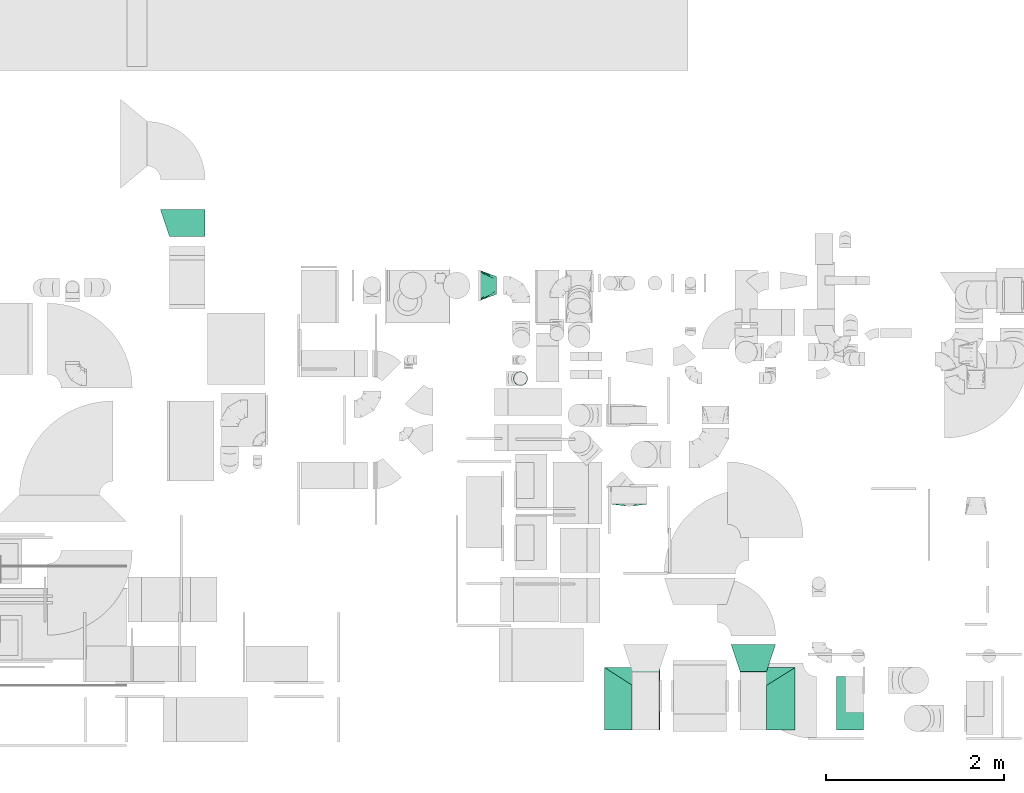
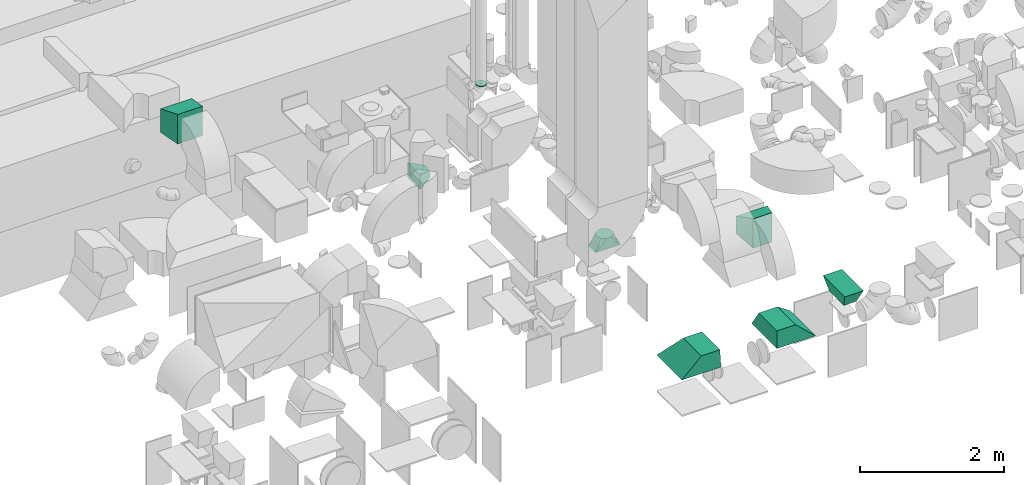
# One storey, part 53 of 59: 8 flow fittings.
"""IFC2X3 building model written with IfcOpenShell, lengths in millimetres."""

import ifcopenshell
import ifcopenshell.guid

model = None  # the IFC model being written
_history = None  # IfcOwnerHistory: only IFC2X3 demands one
_inside = {}  # id of a spatial element -> (the spatial element, [elements in it])
_under = {}  # id of a project, library or spatial element -> (it, [spatial elements below it])
_declared = {}  # id of a project -> (the project, [libraries it declares])
_typed = {}  # id of a type object -> (the type object, [elements of that type])
_made_of = {}  # id of a material, layer set ... -> (it, [elements and type objects made of it])


def new_model(schema):
    """Start an empty IFC model of exactly this schema.

    Asked for "IFC4X3", IfcOpenShell would pick the latest addendum, in which some entities
    have other attributes; the version numbers below select the first issue.
    IFC2X3 requires an IfcOwnerHistory on every rooted entity: one is made here for all.
    """
    global model, _history
    if schema == "IFC4X3":
        model = ifcopenshell.file(schema_version=(4, 3, 0, 0))
    else:
        model = ifcopenshell.file(schema=schema)
    _inside.clear()
    _under.clear()
    _declared.clear()
    _typed.clear()
    _made_of.clear()
    _history = None
    if model.schema == "IFC2X3":
        org = make("IfcOrganization", Name="unknown")
        user = make(
            "IfcPersonAndOrganization",
            ThePerson=make("IfcPerson", FamilyName="unknown"),
            TheOrganization=org,
        )
        app = make(
            "IfcApplication",
            ApplicationDeveloper=org,
            Version="unknown",
            ApplicationFullName="unknown",
            ApplicationIdentifier="unknown",
        )
        _history = make(
            "IfcOwnerHistory",
            OwningUser=user,
            OwningApplication=app,
            ChangeAction="ADDED",
            CreationDate=0,
        )
    return model


def make(cls, **values):
    """One entity of the class cls with the attributes given. An attribute that is None is left unset."""
    return model.create_entity(
        cls, **{name: value for name, value in values.items() if value is not None}
    )


def entity(cls, *values):
    """Any entity or typed value of the class cls, its attributes in the order of the schema. None: left unset."""
    e = model.create_entity(cls)
    for i, value in enumerate(values):
        if value is not None:
            e[i] = value
    return e


def rooted(cls, **values):
    """An entity with a GlobalId (a new one), such as an element, a storey or a relation."""
    return make(cls, GlobalId=ifcopenshell.guid.new(), OwnerHistory=_history, **values)


def si_unit(unit_type, name, prefix=None):
    """IfcSIUnit, for example si_unit("LENGTHUNIT", "METRE", prefix="MILLI")."""
    return make("IfcSIUnit", UnitType=unit_type, Prefix=prefix, Name=name)


def converted_unit(unit_type, name, factor, base, dimensions=None, offset=None):
    """IfcConversionBasedUnit, such as the inch: factor (a typed value) times the base unit."""
    return make(
        "IfcConversionBasedUnit"
        if offset is None
        else "IfcConversionBasedUnitWithOffset",
        ConversionOffset=offset,
        Dimensions=None
        if dimensions is None
        else entity("IfcDimensionalExponents", *dimensions),
        UnitType=unit_type,
        Name=name,
        ConversionFactor=make(
            "IfcMeasureWithUnit", ValueComponent=factor, UnitComponent=base
        ),
    )


def derived_unit(unit_type, elements):
    """IfcDerivedUnit: a product of units, each with its exponent."""
    return make(
        "IfcDerivedUnit",
        Elements=[
            make("IfcDerivedUnitElement", Unit=unit, Exponent=power)
            for unit, power in elements
        ],
        UnitType=unit_type,
    )


def assignment(units):
    """IfcUnitAssignment: the units of a project."""
    return None if units is None else make("IfcUnitAssignment", Units=units)


def point(xyz):
    """IfcCartesianPoint."""
    return None if xyz is None else make("IfcCartesianPoint", Coordinates=xyz)


def direction(xyz):
    """IfcDirection."""
    return None if xyz is None else make("IfcDirection", DirectionRatios=xyz)


def frame(location, z_axis=None, x_axis=None):
    """IfcAxis2Placement3D, a coordinate frame: its origin and axes. An axis left out is left unset."""
    return make(
        "IfcAxis2Placement3D",
        Location=point(location),
        Axis=direction(z_axis),
        RefDirection=direction(x_axis),
    )


def origin():
    """The frame at (0, 0, 0) with its axes left unset."""
    return frame((0.0, 0.0, 0.0))


def place(relative_to, where):
    """IfcLocalPlacement: puts the frame where relative to a parent placement (None: the world)."""
    return make(
        "IfcLocalPlacement", PlacementRelTo=relative_to, RelativePlacement=where
    )


def context(
    kind, dimensions, precision=None, world=None, true_north=None, identifier=None
):
    """IfcGeometricRepresentationContext, for example the 3D "Model" context."""
    return make(
        "IfcGeometricRepresentationContext",
        ContextIdentifier=identifier,
        ContextType=kind,
        CoordinateSpaceDimension=dimensions,
        Precision=precision,
        WorldCoordinateSystem=world,
        TrueNorth=true_north,
    )


def subcontext(parent, identifier, kind, view, scale=None):
    """IfcGeometricRepresentationSubContext, for example "Body" below "Model"."""
    return make(
        "IfcGeometricRepresentationSubContext",
        ContextIdentifier=identifier,
        ContextType=kind,
        ParentContext=parent,
        TargetScale=scale,
        TargetView=view,
    )


def project(units=None, contexts=None):
    """IfcProject with its units and contexts."""
    return rooted(
        "IfcProject",
        Name="project",
        RepresentationContexts=contexts,
        UnitsInContext=assignment(units),
    )


def spatial(cls, under=None, at=None, **own):
    """A site, building, storey or space (cls), placed at a placement, below another one or the project."""
    s = rooted(cls, ObjectPlacement=at, **own)
    if under is not None:
        _under.setdefault(under.id(), (under, []))[1].append(s)
    return s


def faces_of(points, faces, orient=None, outer=None):
    """IfcFace entities. A face is a list of loops; a loop is a list of indices into points, from 0.

    orient and outer hold one flag for each loop. By default every Orientation is true, the
    first loop of a face is its IfcFaceOuterBound and the others are IfcFaceBound.
    """
    made = []
    for i, loops in enumerate(faces):
        bounds = []
        for j, loop in enumerate(loops):
            is_outer = j == 0 if outer is None else outer[i][j]
            bounds.append(
                make(
                    "IfcFaceOuterBound" if is_outer else "IfcFaceBound",
                    Bound=make("IfcPolyLoop", Polygon=[points[k] for k in loop]),
                    Orientation=True if orient is None else orient[i][j],
                )
            )
        made.append(make("IfcFace", Bounds=bounds))
    return made


def faceted_brep(points, faces, orient=None, outer=None, voids=None):
    """IfcFacetedBrep: a solid bounded by flat faces; with voids (closed shells), ...WithVoids."""
    shared = [point(p) for p in points]
    hull = make("IfcClosedShell", CfsFaces=faces_of(shared, faces, orient, outer))
    if voids is None:
        return make("IfcFacetedBrep", Outer=hull)
    return make(
        "IfcFacetedBrepWithVoids",
        Outer=hull,
        Voids=[
            make(cls, CfsFaces=faces_of(shared, fs, o, b)) for cls, fs, o, b in voids
        ],
    )


def shape(context_of_items, identifier, shape_type, items):
    """IfcShapeRepresentation: the items that make up one representation, for example the "Body"."""
    return make(
        "IfcShapeRepresentation",
        ContextOfItems=context_of_items,
        RepresentationIdentifier=identifier,
        RepresentationType=shape_type,
        Items=items,
    )


def source(mapping_origin, context_of_items, identifier, shape_type, items):
    """IfcRepresentationMap: a shape defined once, which mapped items show again and again."""
    return make(
        "IfcRepresentationMap",
        MappingOrigin=mapping_origin,
        MappedRepresentation=shape(context_of_items, identifier, shape_type, items),
    )


def transform(
    local_origin,
    x_axis=None,
    y_axis=None,
    z_axis=None,
    scale=None,
    scale2=None,
    scale3=None,
    uniform=True,
):
    """IfcCartesianTransformationOperator3D, or its non-uniform kind. x_axis, y_axis, z_axis: its Axis1, 2, 3."""
    if uniform:
        return make(
            "IfcCartesianTransformationOperator3D",
            Axis1=direction(x_axis),
            Axis2=direction(y_axis),
            LocalOrigin=point(local_origin),
            Scale=scale,
            Axis3=direction(z_axis),
        )
    return make(
        "IfcCartesianTransformationOperator3DnonUniform",
        Axis1=direction(x_axis),
        Axis2=direction(y_axis),
        LocalOrigin=point(local_origin),
        Scale=scale,
        Axis3=direction(z_axis),
        Scale2=scale2,
        Scale3=scale3,
    )


def mapped(mapping_source, mapping_target):
    """IfcMappedItem: shows the shape of a source again, moved by a transform."""
    return make(
        "IfcMappedItem", MappingSource=mapping_source, MappingTarget=mapping_target
    )


def material(Name=None, Category=None):
    """IfcMaterial."""
    return make("IfcMaterial", Name=Name, Category=Category)


def made_of(thing, what):
    """Note that an element or type object is made of a material, layer set ...; save() writes the relation."""
    if what is not None:
        _made_of.setdefault(what.id(), (what, []))[1].append(thing)
    return thing


def type_object(cls, material=None, **own):
    """A type object (cls), such as IfcWallType, which elements share."""
    return made_of(rooted(cls, **own), material)


def type_shapes(of_type, sources):
    """Give a type object the sources (RepresentationMaps) that its elements show as mapped items."""
    of_type.RepresentationMaps = sources


def element(
    cls,
    number,
    at=None,
    inside=None,
    cuts=None,
    type_object=None,
    material=None,
    context=None,
    identifier="Body",
    shape_type=None,
    held_by="IfcProductDefinitionShape",
    body=None,
    shapes=None,
    **own,
):
    """One element of the class cls, such as IfcWall. Its Tag is "e" and its number.

    at: its placement. inside: the storey or other place that contains it. cuts: it is an
    opening in that element (IfcRelVoidsElement). A single representation is given by context,
    identifier, shape_type and body (its items); several are given by shapes. held_by: the class
    of the entity that holds the representations. save() writes the other relations.
    """
    e = rooted(cls, Tag="e%d" % number, ObjectPlacement=at, **own)
    if body is not None:
        shapes = [shape(context, identifier, shape_type, body)]
    if shapes is not None:
        e.Representation = make(held_by, Representations=shapes)
    if inside is not None:
        _inside.setdefault(inside.id(), (inside, []))[1].append(e)
    if cuts is not None:
        rooted(
            "IfcRelVoidsElement", RelatingBuildingElement=cuts, RelatedOpeningElement=e
        )
    if type_object is not None:
        _typed.setdefault(type_object.id(), (type_object, []))[1].append(e)
    return made_of(e, material)


def aggregate(whole, parts):
    """IfcRelAggregates: a whole, such as a stair, and the parts it consists of."""
    return rooted("IfcRelAggregates", RelatingObject=whole, RelatedObjects=parts)


def save(model, path):
    """Write the relations noted so far, then the file.

    IfcRelAggregates (storeys below a building ...), IfcRelContainedInSpatialStructure (elements
    in a storey), IfcRelDefinesByType, IfcRelAssociatesMaterial and IfcRelDeclares: one each for
    every whole, place, type object, material and project.
    """
    for whole, parts in _under.values():
        aggregate(whole, parts)
    for where, things in _inside.values():
        rooted(
            "IfcRelContainedInSpatialStructure",
            RelatedElements=things,
            RelatingStructure=where,
        )
    for kind, things in _typed.values():
        rooted("IfcRelDefinesByType", RelatedObjects=things, RelatingType=kind)
    for what, things in _made_of.values():
        rooted("IfcRelAssociatesMaterial", RelatedObjects=things, RelatingMaterial=what)
    for by, libraries in _declared.values():
        rooted("IfcRelDeclares", RelatingContext=by, RelatedDefinitions=libraries)
    model.write(path)


model = new_model("IFC2X3")

# Units and contexts
model_context = context("Model", 3, precision=0.01, world=origin(), true_north=direction((6.12303176911189e-17, 1.0)))
body_context = subcontext(model_context, "Body", "Model", "MODEL_VIEW")
ifc_project = project(units=[si_unit("LENGTHUNIT", "METRE", prefix="MILLI"), si_unit("AREAUNIT", "SQUARE_METRE"), si_unit("VOLUMEUNIT", "CUBIC_METRE"), converted_unit("PLANEANGLEUNIT", "DEGREE", entity("IfcRatioMeasure", 0.0174532925199433), si_unit("PLANEANGLEUNIT", "RADIAN"), dimensions=[0, 0, 0, 0, 0, 0, 0]), si_unit("MASSUNIT", "GRAM", prefix="KILO"), derived_unit("MASSDENSITYUNIT", [(si_unit("MASSUNIT", "GRAM", prefix="KILO"), 1), (si_unit("LENGTHUNIT", "METRE"), -3)]), derived_unit("MOMENTOFINERTIAUNIT", [(si_unit("LENGTHUNIT", "METRE"), 4)]), si_unit("TIMEUNIT", "SECOND"), si_unit("FREQUENCYUNIT", "HERTZ"), si_unit("THERMODYNAMICTEMPERATUREUNIT", "DEGREE_CELSIUS"), derived_unit("THERMALTRANSMITTANCEUNIT", [(si_unit("MASSUNIT", "GRAM", prefix="KILO"), 1), (si_unit("THERMODYNAMICTEMPERATUREUNIT", "KELVIN"), -1), (si_unit("TIMEUNIT", "SECOND"), -3)]), derived_unit("VOLUMETRICFLOWRATEUNIT", [(si_unit("LENGTHUNIT", "METRE"), 3), (si_unit("TIMEUNIT", "SECOND"), -1)]), derived_unit("MASSFLOWRATEUNIT", [(si_unit("MASSUNIT", "GRAM", prefix="KILO"), 1), (si_unit("TIMEUNIT", "SECOND"), -1)]), derived_unit("ROTATIONALFREQUENCYUNIT", [(si_unit("TIMEUNIT", "SECOND"), -1)]), si_unit("ELECTRICCURRENTUNIT", "AMPERE"), si_unit("ELECTRICVOLTAGEUNIT", "VOLT"), si_unit("POWERUNIT", "WATT"), si_unit("FORCEUNIT", "NEWTON", prefix="KILO"), si_unit("ILLUMINANCEUNIT", "LUX"), si_unit("LUMINOUSFLUXUNIT", "LUMEN"), si_unit("LUMINOUSINTENSITYUNIT", "CANDELA"), derived_unit("USERDEFINED", [(si_unit("MASSUNIT", "GRAM", prefix="KILO"), -1), (si_unit("LENGTHUNIT", "METRE"), -2), (si_unit("TIMEUNIT", "SECOND"), 3), (si_unit("LUMINOUSFLUXUNIT", "LUMEN"), 1)]), derived_unit("LINEARVELOCITYUNIT", [(si_unit("LENGTHUNIT", "METRE"), 1), (si_unit("TIMEUNIT", "SECOND"), -1)]), si_unit("PRESSUREUNIT", "PASCAL"), derived_unit("USERDEFINED", [(si_unit("LENGTHUNIT", "METRE"), -2), (si_unit("MASSUNIT", "GRAM", prefix="KILO"), 1), (si_unit("TIMEUNIT", "SECOND"), -2)]), derived_unit("LINEARFORCEUNIT", [(si_unit("MASSUNIT", "GRAM", prefix="KILO"), 1), (si_unit("LENGTHUNIT", "METRE"), 1), (si_unit("TIMEUNIT", "SECOND"), -2), (si_unit("LENGTHUNIT", "METRE"), -1)]), derived_unit("PLANARFORCEUNIT", [(si_unit("MASSUNIT", "GRAM", prefix="KILO"), 1), (si_unit("LENGTHUNIT", "METRE"), 1), (si_unit("TIMEUNIT", "SECOND"), -2), (si_unit("LENGTHUNIT", "METRE"), -2)])], contexts=[model_context])

# Site, building, storey
site_placement = place(None, origin())
site = spatial("IfcSite", under=ifc_project, at=site_placement, CompositionType="ELEMENT")
building_placement = place(site_placement, origin())
building = spatial("IfcBuilding", under=site, at=building_placement, CompositionType="ELEMENT")
storey_placement = place(building_placement, frame((0.0, 0.0, 28200.0)))
storey = spatial("IfcBuildingStorey", under=building, at=storey_placement, CompositionType="ELEMENT", Elevation=28200.0)

# Flow fittings
ifc_material = material()
duct_fitting_type_1 = type_object("IfcDuctFittingType", PredefinedType="NOTDEFINED", material=ifc_material)
shared_shape_1 = source(origin(), body_context, "Body", "Brep", [
    faceted_brep([(200.0, 30.9, 95.11), (200.0, 19.08, 96.98), (200.0, 9.54, 98.49), (200.0, 4.77, 99.24), (200.0, 0.0, 100.0), (200.0, -4.77, 99.24), (200.0, -9.54, 98.49), (200.0, -19.08, 96.98), (200.0, -30.9, 95.11), (200.0, -44.84, 88.0), (200.0, -58.78, 80.9), (200.0, -69.84, 69.84), (200.0, -80.9, 58.78), (200.0, -88.0, 44.84), (200.0, -95.11, 30.9), (200.0, -96.98, 19.08), (200.0, -98.49, 9.54), (200.0, -99.24, 4.77), (200.0, -100.0, 0.0), (200.0, -99.24, -4.77), (200.0, -98.49, -9.54), (200.0, -96.98, -19.08), (200.0, -95.11, -30.9), (200.0, -88.0, -44.84), (200.0, -80.9, -58.78), (200.0, -69.84, -69.84), (200.0, -58.78, -80.9), (200.0, -44.84, -88.0), (200.0, -30.9, -95.11), (200.0, -19.08, -96.98), (200.0, -9.54, -98.49), (200.0, -4.77, -99.24), (200.0, 0.0, -100.0), (200.0, 4.77, -99.24), (200.0, 9.54, -98.49), (200.0, 19.08, -96.98), (200.0, 30.9, -95.11), (200.0, 44.84, -88.0), (200.0, 58.78, -80.9), (200.0, 69.84, -69.84), (200.0, 80.9, -58.78), (200.0, 88.0, -44.84), (200.0, 95.11, -30.9), (200.0, 96.98, -19.08), (200.0, 98.49, -9.54), (200.0, 99.24, -4.77), (200.0, 100.0, 0.0), (200.0, 99.24, 4.77), (200.0, 98.49, 9.54), (200.0, 96.98, 19.08), (200.0, 95.11, 30.9), (200.0, 88.0, 44.84), (200.0, 80.9, 58.78), (200.0, 69.84, 69.84), (200.0, 58.78, 80.9), (200.0, 44.84, 88.0), (0.0, -175.0, 125.0), (0.0, 175.0, 125.0), (0.0, 175.0, -125.0), (0.0, -175.0, -125.0), (104.11, -83.9, 111.99), (100.0, -120.65, 99.93), (26.03, -152.23, 121.75), (78.09, -106.68, 115.24), (52.06, -129.45, 118.49), (188.01, -10.49, 101.5), (176.03, -20.98, 103.0), (152.06, -41.95, 105.99), (128.09, -62.93, 108.99), (52.06, -155.48, 92.46), (78.09, -145.72, 76.2), (104.11, -135.96, 59.93), (128.09, -126.97, 44.95), (152.06, -117.98, 29.96), (176.03, -108.99, 14.98), (188.01, -104.49, 7.49), (26.03, -165.24, 108.73), (26.03, -165.24, -108.73), (52.06, -155.48, -92.46), (78.09, -145.72, -76.2), (104.11, -135.96, -59.93), (128.09, -126.97, -44.95), (152.06, -117.98, -29.96), (176.03, -108.99, -14.98), (188.01, -104.49, -7.49), (100.0, -124.93, -95.65), (52.06, -129.45, -118.49), (78.09, -106.68, -115.24), (104.11, -83.9, -111.99), (128.09, -62.93, -108.99), (152.06, -41.95, -105.99), (176.03, -20.98, -103.0), (188.01, -10.49, -101.5), (26.03, -152.23, -121.75), (26.03, 152.23, -121.75), (52.06, 129.45, -118.49), (78.09, 106.68, -115.24), (104.11, 83.9, -111.99), (128.09, 62.93, -108.99), (152.06, 41.95, -105.99), (176.03, 20.98, -103.0), (188.01, 10.49, -101.5), (100.0, 120.65, -99.93), (52.06, 155.48, -92.46), (78.09, 145.72, -76.2), (104.11, 135.96, -59.93), (128.09, 126.97, -44.95), (152.06, 117.98, -29.96), (176.03, 108.99, -14.98), (188.01, 104.49, -7.49), (26.03, 165.24, -108.73), (26.03, 165.24, 108.73), (52.06, 155.48, 92.46), (78.09, 145.72, 76.2), (104.11, 135.96, 59.93), (128.09, 126.97, 44.95), (152.06, 117.98, 29.96), (176.03, 108.99, 14.98), (188.01, 104.49, 7.49), (100.0, 124.93, 95.65), (52.06, 129.45, 118.49), (78.09, 106.68, 115.24), (104.11, 83.9, 111.99), (128.09, 62.93, 108.99), (152.06, 41.95, 105.99), (176.03, 20.98, 103.0), (188.01, 10.49, 101.5), (26.03, 152.23, 121.75)], [[[0, 1, 2, 3, 4, 5, 6, 7, 8, 9, 10, 11, 12, 13, 14, 15, 16, 17, 18, 19, 20, 21, 22, 23, 24, 25, 26, 27, 28, 29, 30, 31, 32, 33, 34, 35, 36, 37, 38, 39, 40, 41, 42, 43, 44, 45, 46, 47, 48, 49, 50, 51, 52, 53, 54, 55]], [[56, 57, 58, 59]], [[60, 9, 8]], [[56, 61, 62]], [[9, 60, 63, 64]], [[65, 66, 67, 68, 60, 8, 7, 6, 5, 4]], [[62, 61, 10]], [[13, 69, 70, 71]], [[64, 10, 9]], [[14, 71, 72, 73, 74, 75, 18, 17, 16, 15]], [[12, 76, 69]], [[71, 14, 13]], [[61, 76, 11]], [[10, 64, 62]], [[76, 12, 11]], [[10, 61, 11]], [[61, 56, 76]], [[69, 13, 12]], [[75, 74, 73, 72, 71, 70, 69, 76, 56, 59, 77, 78, 79, 80, 81, 82, 83, 84, 18]], [[80, 23, 22]], [[59, 85, 77]], [[23, 80, 79, 78]], [[84, 83, 82, 81, 80, 22, 21, 20, 19, 18]], [[77, 85, 24]], [[27, 86, 87, 88]], [[78, 24, 23]], [[28, 88, 89, 90, 91, 92, 32, 31, 30, 29]], [[26, 93, 86]], [[88, 28, 27]], [[85, 93, 25]], [[24, 78, 77]], [[93, 26, 25]], [[24, 85, 25]], [[85, 59, 93]], [[86, 27, 26]], [[92, 91, 90, 89, 88, 87, 86, 93, 59, 58, 94, 95, 96, 97, 98, 99, 100, 101, 32]], [[97, 37, 36]], [[58, 102, 94]], [[37, 97, 96, 95]], [[101, 100, 99, 98, 97, 36, 35, 34, 33, 32]], [[94, 102, 38]], [[41, 103, 104, 105]], [[95, 38, 37]], [[42, 105, 106, 107, 108, 109, 46, 45, 44, 43]], [[40, 110, 103]], [[105, 42, 41]], [[102, 110, 39]], [[38, 95, 94]], [[110, 40, 39]], [[38, 102, 39]], [[102, 58, 110]], [[103, 41, 40]], [[58, 57, 111, 112, 113, 114, 115, 116, 117, 118, 46, 109, 108, 107, 106, 105, 104, 103, 110]], [[114, 51, 50]], [[57, 119, 111]], [[51, 114, 113, 112]], [[118, 117, 116, 115, 114, 50, 49, 48, 47, 46]], [[111, 119, 52]], [[55, 120, 121, 122]], [[112, 52, 51]], [[0, 122, 123, 124, 125, 126, 4, 3, 2, 1]], [[54, 127, 120]], [[122, 0, 55]], [[119, 127, 53]], [[52, 112, 111]], [[127, 54, 53]], [[52, 119, 53]], [[119, 57, 127]], [[120, 55, 54]], [[57, 56, 62, 64, 63, 60, 68, 67, 66, 65, 4, 126, 125, 124, 123, 122, 121, 120, 127]]]),
])
type_shapes(duct_fitting_type_1, [shared_shape_1])
flow_fitting_1_placement = place(storey_placement, frame((47889.82, 12999.59, 1825.0)))
element("IfcFlowFitting", 1, at=flow_fitting_1_placement, inside=storey, type_object=duct_fitting_type_1, material=ifc_material, context=body_context, shape_type="MappedRepresentation", body=[
    mapped(shared_shape_1, transform((0.0, 0.0, 0.0), scale=1.0)),
])
duct_fitting_type_2 = type_object("IfcDuctFittingType", PredefinedType="NOTDEFINED", material=ifc_material)
shared_shape_2 = source(origin(), body_context, "Body", "Brep", [
    faceted_brep([(300.0, -150.0, 250.0), (300.0, -150.0, -250.0), (300.0, 150.0, -250.0), (300.0, 150.0, 250.0), (0.0, -250.0, 150.0), (0.0, 250.0, 150.0), (0.0, 250.0, -150.0), (0.0, -250.0, -150.0)], [[[0, 1, 2, 3]], [[4, 5, 6, 7]], [[4, 7, 1, 0]], [[7, 6, 2, 1]], [[6, 5, 3, 2]], [[5, 4, 0, 3]]]),
])
type_shapes(duct_fitting_type_2, [shared_shape_2])
flow_fitting_2_placement = place(storey_placement, frame((50974.61, 8966.84, 2450.0), z_axis=(0.0, 0.0, 1.0), x_axis=(0.0, -1.0, 0.0)))
element("IfcFlowFitting", 2, at=flow_fitting_2_placement, inside=storey, type_object=duct_fitting_type_2, material=ifc_material, context=body_context, shape_type="MappedRepresentation", body=[
    mapped(shared_shape_2, transform((0.0, 0.0, 0.0), scale=1.0)),
])
duct_fitting_type_3 = type_object("IfcDuctFittingType", PredefinedType="NOTDEFINED", material=ifc_material)
shared_shape_3 = source(origin(), body_context, "Body", "Brep", [
    faceted_brep([(300.0, -300.0, 350.0), (300.0, -300.0, -150.0), (300.0, 0.0, -150.0), (300.0, 0.0, 350.0), (0.0, -310.0, 350.0), (0.0, 310.0, 350.0), (0.0, 310.0, -350.0), (0.0, -310.0, -350.0)], [[[0, 1, 2, 3]], [[4, 5, 6, 7]], [[4, 7, 1, 0]], [[7, 6, 2, 1]], [[6, 5, 3, 2]], [[5, 4, 0, 3]]]),
])
type_shapes(duct_fitting_type_3, [shared_shape_3])
flow_fitting_3_placement = place(storey_placement, frame((49615.11, 8360.0, 900.0), z_axis=(0.0, -1.0, 0.0), x_axis=(0.0, 0.0, 1.0)))
element("IfcFlowFitting", 3, at=flow_fitting_3_placement, inside=storey, type_object=duct_fitting_type_3, material=ifc_material, context=body_context, shape_type="MappedRepresentation", body=[
    mapped(shared_shape_3, transform((0.0, 0.0, 0.0), scale=1.0)),
])
duct_fitting_type_4 = type_object("IfcDuctFittingType", PredefinedType="NOTDEFINED", material=ifc_material)
shared_shape_4 = source(origin(), body_context, "Body", "Brep", [
    faceted_brep([(300.0, 10.0, 350.0), (300.0, 10.0, -150.0), (300.0, 310.0, -150.0), (300.0, 310.0, 350.0), (0.0, -310.0, 350.0), (0.0, 310.0, 350.0), (0.0, 310.0, -350.0), (0.0, -310.0, -350.0)], [[[0, 1, 2, 3]], [[4, 5, 6, 7]], [[4, 7, 1, 0]], [[7, 6, 2, 1]], [[6, 5, 3, 2]], [[5, 4, 0, 3]]]),
])
type_shapes(duct_fitting_type_4, [shared_shape_4])
flow_fitting_4_placement = place(storey_placement, frame((51134.61, 8360.0, 900.0), z_axis=(0.0, -1.0, 0.0), x_axis=(0.0, 0.0, 1.0)))
element("IfcFlowFitting", 4, at=flow_fitting_4_placement, inside=storey, type_object=duct_fitting_type_4, material=ifc_material, context=body_context, shape_type="MappedRepresentation", body=[
    mapped(shared_shape_4, transform((0.0, 0.0, 0.0), scale=1.0)),
])
duct_fitting_type_5 = type_object("IfcDuctFittingType", PredefinedType="NOTDEFINED", material=ifc_material)
shared_shape_5 = source(origin(), body_context, "Body", "Brep", [
    faceted_brep([(200.0, -73.47, 101.13), (200.0, -87.3, 87.3), (200.0, -101.13, 73.47), (200.0, -110.0, 56.05), (200.0, -118.88, 38.63), (200.0, -121.22, 23.84), (200.0, -123.11, 11.92), (200.0, -124.06, 5.96), (200.0, -125.0, 0.0), (200.0, -124.06, -5.96), (200.0, -123.11, -11.92), (200.0, -121.22, -23.84), (200.0, -118.88, -38.63), (200.0, -110.0, -56.05), (200.0, -101.13, -73.47), (200.0, -87.3, -87.3), (200.0, -73.47, -101.13), (200.0, -56.05, -110.0), (200.0, -38.63, -118.88), (200.0, -23.84, -121.22), (200.0, -11.92, -123.11), (200.0, -5.96, -124.06), (200.0, 0.0, -125.0), (200.0, 5.96, -124.06), (200.0, 11.92, -123.11), (200.0, 23.84, -121.22), (200.0, 38.63, -118.88), (200.0, 56.05, -110.0), (200.0, 73.47, -101.13), (200.0, 87.3, -87.3), (200.0, 101.13, -73.47), (200.0, 110.0, -56.05), (200.0, 118.88, -38.63), (200.0, 121.22, -23.84), (200.0, 123.11, -11.92), (200.0, 124.06, -5.96), (200.0, 125.0, 0.0), (200.0, 124.06, 5.96), (200.0, 123.11, 11.92), (200.0, 121.22, 23.84), (200.0, 118.88, 38.63), (200.0, 110.0, 56.05), (200.0, 101.13, 73.47), (200.0, 87.3, 87.3), (200.0, 73.47, 101.13), (200.0, 56.05, 110.0), (200.0, 38.63, 118.88), (200.0, 23.84, 121.22), (200.0, 11.92, 123.11), (200.0, 5.96, 124.06), (200.0, 0.0, 125.0), (200.0, -5.96, 124.06), (200.0, -11.92, 123.11), (200.0, -23.84, 121.22), (200.0, -38.63, 118.88), (200.0, -56.05, 110.0), (0.0, 100.0, -200.0), (0.0, -100.0, -200.0), (0.0, -100.0, 200.0), (0.0, 100.0, 200.0), (104.11, 47.94, 160.96), (26.03, 86.99, 190.24), (100.0, 91.44, 146.79), (128.09, 35.96, 151.97), (152.06, 23.97, 142.98), (176.03, 11.99, 133.99), (188.01, 5.99, 129.49), (52.06, 106.51, 147.94), (26.03, 103.25, 173.97), (78.09, 109.76, 121.91), (104.11, 113.01, 95.89), (188.01, 123.5, 11.99), (176.03, 122.0, 23.97), (152.06, 119.01, 47.94), (128.09, 116.01, 71.91), (52.06, 73.97, 180.48), (78.09, 60.96, 170.72), (188.01, 123.5, -11.99), (176.03, 122.0, -23.97), (152.06, 119.01, -47.94), (128.09, 116.01, -71.91), (104.11, 113.01, -95.89), (78.09, 109.76, -121.91), (52.06, 106.51, -147.94), (26.03, 103.25, -173.97), (100.0, 96.79, -141.44), (52.06, 73.97, -180.48), (26.03, 86.99, -190.24), (78.09, 60.96, -170.72), (104.11, 47.94, -160.96), (188.01, 5.99, -129.49), (176.03, 11.99, -133.99), (152.06, 23.97, -142.98), (128.09, 35.96, -151.97), (188.01, -5.99, -129.49), (176.03, -11.99, -133.99), (152.06, -23.97, -142.98), (128.09, -35.96, -151.97), (104.11, -47.94, -160.96), (78.09, -60.96, -170.72), (52.06, -73.97, -180.48), (26.03, -86.99, -190.24), (100.0, -91.44, -146.79), (52.06, -106.51, -147.94), (26.03, -103.25, -173.97), (78.09, -109.76, -121.91), (104.11, -113.01, -95.89), (188.01, -123.5, -11.99), (176.03, -122.0, -23.97), (152.06, -119.01, -47.94), (128.09, -116.01, -71.91), (188.01, -123.5, 11.99), (176.03, -122.0, 23.97), (152.06, -119.01, 47.94), (128.09, -116.01, 71.91), (104.11, -113.01, 95.89), (78.09, -109.76, 121.91), (52.06, -106.51, 147.94), (26.03, -103.25, 173.97), (100.0, -96.79, 141.44), (52.06, -73.97, 180.48), (26.03, -86.99, 190.24), (78.09, -60.96, 170.72), (104.11, -47.94, 160.96), (188.01, -5.99, 129.49), (176.03, -11.99, 133.99), (152.06, -23.97, 142.98), (128.09, -35.96, 151.97)], [[[0, 1, 2, 3, 4, 5, 6, 7, 8, 9, 10, 11, 12, 13, 14, 15, 16, 17, 18, 19, 20, 21, 22, 23, 24, 25, 26, 27, 28, 29, 30, 31, 32, 33, 34, 35, 36, 37, 38, 39, 40, 41, 42, 43, 44, 45, 46, 47, 48, 49, 50, 51, 52, 53, 54, 55]], [[56, 57, 58, 59]], [[46, 45, 60]], [[61, 62, 59]], [[60, 63, 64, 65, 66, 50, 49, 48, 47, 46]], [[67, 68, 42]], [[44, 62, 61]], [[69, 67, 41, 70]], [[39, 38, 37, 36, 71, 72, 73, 74, 70, 40]], [[45, 44, 75]], [[76, 60, 45, 75]], [[41, 40, 70]], [[43, 68, 62]], [[61, 75, 44]], [[43, 42, 68]], [[43, 62, 44]], [[68, 59, 62]], [[42, 41, 67]], [[56, 59, 68, 67, 69, 70, 74, 73, 72, 71, 36, 77, 78, 79, 80, 81, 82, 83, 84]], [[32, 31, 81]], [[84, 85, 56]], [[81, 80, 79, 78, 77, 36, 35, 34, 33, 32]], [[86, 87, 28]], [[30, 85, 84]], [[88, 86, 27, 89]], [[25, 24, 23, 22, 90, 91, 92, 93, 89, 26]], [[31, 30, 83]], [[82, 81, 31, 83]], [[27, 26, 89]], [[29, 87, 85]], [[84, 83, 30]], [[29, 28, 87]], [[29, 85, 30]], [[87, 56, 85]], [[28, 27, 86]], [[57, 56, 87, 86, 88, 89, 93, 92, 91, 90, 22, 94, 95, 96, 97, 98, 99, 100, 101]], [[18, 17, 98]], [[101, 102, 57]], [[98, 97, 96, 95, 94, 22, 21, 20, 19, 18]], [[103, 104, 14]], [[16, 102, 101]], [[105, 103, 13, 106]], [[11, 10, 9, 8, 107, 108, 109, 110, 106, 12]], [[17, 16, 100]], [[99, 98, 17, 100]], [[13, 12, 106]], [[15, 104, 102]], [[101, 100, 16]], [[15, 14, 104]], [[15, 102, 16]], [[104, 57, 102]], [[14, 13, 103]], [[111, 112, 113, 114, 115, 116, 117, 118, 58, 57, 104, 103, 105, 106, 110, 109, 108, 107, 8]], [[4, 3, 115]], [[118, 119, 58]], [[115, 114, 113, 112, 111, 8, 7, 6, 5, 4]], [[120, 121, 0]], [[2, 119, 118]], [[122, 120, 55, 123]], [[53, 52, 51, 50, 124, 125, 126, 127, 123, 54]], [[3, 2, 117]], [[116, 115, 3, 117]], [[55, 54, 123]], [[1, 121, 119]], [[118, 117, 2]], [[1, 0, 121]], [[1, 119, 2]], [[121, 58, 119]], [[0, 55, 120]], [[66, 65, 64, 63, 60, 76, 75, 61, 59, 58, 121, 120, 122, 123, 127, 126, 125, 124, 50]]]),
])
type_shapes(duct_fitting_type_5, [shared_shape_5])
flow_fitting_5_placement = place(storey_placement, frame((49582.71, 10643.71, 1490.0), z_axis=(1.0, 0.0, 0.0), x_axis=(0.0, 0.0, 1.0)))
element("IfcFlowFitting", 5, at=flow_fitting_5_placement, inside=storey, type_object=duct_fitting_type_5, material=ifc_material, context=body_context, shape_type="MappedRepresentation", body=[
    mapped(shared_shape_5, transform((0.0, 0.0, 0.0), scale=1.0)),
])
duct_fitting_type_6 = type_object("IfcDuctFittingType", PredefinedType="NOTDEFINED", material=ifc_material)
shared_shape_6 = source(origin(), body_context, "Body", "Brep", [
    faceted_brep([(300.0, -200.0, 200.0), (300.0, -200.0, -400.0), (300.0, 100.0, -400.0), (300.0, 100.0, 200.0), (0.0, -100.0, 200.0), (0.0, 100.0, 200.0), (0.0, 100.0, -200.0), (0.0, -100.0, -200.0)], [[[0, 1, 2, 3]], [[4, 5, 6, 7]], [[4, 7, 1, 0]], [[7, 6, 2, 1]], [[6, 5, 3, 2]], [[5, 4, 0, 3]]]),
])
type_shapes(duct_fitting_type_6, [shared_shape_6])
flow_fitting_6_placement = place(storey_placement, frame((52110.61, 8406.69, 1097.0), z_axis=(0.0, 1.0, 0.0), x_axis=(0.0, 0.0, 1.0)))
element("IfcFlowFitting", 6, at=flow_fitting_6_placement, inside=storey, type_object=duct_fitting_type_6, material=ifc_material, context=body_context, shape_type="MappedRepresentation", body=[
    mapped(shared_shape_6, transform((0.0, 0.0, 0.0), scale=1.0)),
])
duct_fitting_type_7 = type_object("IfcDuctFittingType", PredefinedType="NOTDEFINED", material=ifc_material)
shared_shape_7 = source(origin(), body_context, "Body", "Brep", [
    faceted_brep([(300.0, -200.0, 200.0), (300.0, -200.0, -200.0), (300.0, 300.0, -200.0), (300.0, 300.0, 200.0), (0.0, -200.0, 250.0), (0.0, 200.0, 250.0), (0.0, 200.0, -250.0), (0.0, -200.0, -250.0)], [[[0, 1, 2, 3]], [[4, 5, 6, 7]], [[4, 7, 1, 0]], [[7, 6, 2, 1]], [[6, 5, 3, 2]], [[5, 4, 0, 3]]]),
])
type_shapes(duct_fitting_type_7, [shared_shape_7])
flow_fitting_7_placement = place(storey_placement, frame((44620.31, 13549.12, 3500.0), z_axis=(0.0, 0.0, 1.0), x_axis=(0.0, 1.0, 0.0)))
element("IfcFlowFitting", 7, at=flow_fitting_7_placement, inside=storey, type_object=duct_fitting_type_7, material=ifc_material, context=body_context, shape_type="MappedRepresentation", body=[
    mapped(shared_shape_7, transform((0.0, 0.0, 0.0), scale=1.0)),
])
duct_fitting_type_8 = type_object("IfcDuctFittingType", PredefinedType="NOTDEFINED", material=ifc_material)
shared_shape_8 = source(origin(), body_context, "Body", "Brep", [
    faceted_brep([(10.0, 3.18, -5.5), (10.0, 28.7, -69.29), (10.0, 40.87, -61.16), (10.0, 1.64, -6.13), (10.0, 53.03, -53.03), (10.0, 4.49, -4.49), (10.0, 18.12, -71.4), (10.0, 0.0, -75.0), (10.0, 0.0, -6.35), (10.0, -1.64, -6.13), (10.0, -14.35, -72.15), (10.0, -28.7, -69.29), (10.0, -3.17, -5.5), (10.0, -40.87, -61.16), (10.0, -53.03, -53.03), (10.0, -4.49, -4.49), (10.0, -5.5, -3.18), (10.0, -61.16, -40.87), (10.0, -69.29, -28.7), (10.0, -6.13, -1.64), (10.0, -71.4, -18.12), (10.0, -75.0, 0.0), (10.0, -6.35, 0.0), (10.0, -6.13, 1.64), (10.0, -72.15, 14.35), (10.0, -69.29, 28.7), (10.0, -5.5, 3.17), (10.0, -61.16, 40.87), (10.0, -53.03, 53.03), (10.0, -4.49, 4.49), (10.0, -3.17, 5.5), (10.0, -40.87, 61.16), (10.0, -28.7, 69.29), (10.0, -1.64, 6.13), (10.0, -18.12, 71.4), (10.0, 0.0, 75.0), (10.0, 0.0, 6.35), (10.0, 1.64, 6.13), (10.0, 14.35, 72.15), (10.0, 28.7, 69.29), (10.0, 3.18, 5.5), (10.0, 40.87, 61.16), (10.0, 53.03, 53.03), (10.0, 4.49, 4.49), (10.0, 5.5, 3.17), (10.0, 61.16, 40.87), (10.0, 69.29, 28.7), (10.0, 6.13, 1.64), (10.0, 71.4, 18.12), (10.0, 75.0, 0.0), (10.0, 6.35, 0.0), (10.0, 6.13, -1.64), (10.0, 72.15, -14.35), (10.0, 69.29, -28.7), (10.0, 5.5, -3.18), (10.0, 61.16, -40.87), (0.0, 3.18, -5.5), (0.0, 56.57, -56.57), (0.0, 43.59, -65.24), (0.0, 4.49, -4.49), (0.0, 30.61, -73.91), (0.0, 1.64, -6.13), (0.0, 5.5, -3.17), (0.0, 65.24, -43.59), (0.0, 73.91, -30.61), (0.0, 6.13, -1.64), (0.0, 76.16, -19.33), (0.0, 80.0, 0.0), (0.0, 6.35, 0.0), (0.0, 6.13, 1.64), (0.0, 76.96, 15.31), (0.0, 73.91, 30.61), (0.0, 5.5, 3.18), (0.0, 65.24, 43.59), (0.0, 56.57, 56.57), (0.0, 4.49, 4.49), (0.0, 3.18, 5.5), (0.0, 43.59, 65.24), (0.0, 30.61, 73.91), (0.0, 1.64, 6.13), (0.0, 19.33, 76.16), (0.0, 0.0, 80.0), (0.0, 0.0, 6.35), (0.0, -1.64, 6.13), (0.0, -15.31, 76.96), (0.0, -30.61, 73.91), (0.0, -3.17, 5.5), (0.0, -43.59, 65.24), (0.0, -56.57, 56.57), (0.0, -4.49, 4.49), (0.0, -5.5, 3.18), (0.0, -65.24, 43.59), (0.0, -73.91, 30.61), (0.0, -6.13, 1.64), (0.0, -76.16, 19.33), (0.0, -80.0, 0.0), (0.0, -6.35, 0.0), (0.0, -6.13, -1.64), (0.0, -76.96, -15.31), (0.0, -73.91, -30.61), (0.0, -5.5, -3.17), (0.0, -65.24, -43.59), (0.0, -56.57, -56.57), (0.0, -4.49, -4.49), (0.0, -3.17, -5.5), (0.0, -43.59, -65.24), (0.0, -30.61, -73.91), (0.0, -1.64, -6.13), (0.0, -19.33, -76.16), (0.0, 0.0, -80.0), (0.0, 0.0, -6.35), (0.0, 15.31, -76.96), (-2.7, 3.18, -5.5), (-2.7, 1.64, -6.13), (-2.7, 0.0, -6.35), (-2.7, -1.64, -6.13), (-2.7, -3.17, -5.5), (-2.7, -4.49, -4.49), (-2.7, -5.5, -3.17), (-2.7, -6.13, -1.64), (-2.7, -6.35, 0.0), (-2.7, -6.13, 1.64), (-2.7, -5.5, 3.18), (-2.7, -4.49, 4.49), (-2.7, -3.17, 5.5), (-2.7, -1.64, 6.13), (-2.7, 0.0, 6.35), (-2.7, 1.64, 6.13), (-2.7, 3.18, 5.5), (-2.7, 4.49, 4.49), (-2.7, 5.5, 3.18), (-2.7, 6.13, 1.64), (-2.7, 6.35, 0.0), (-2.7, 6.13, -1.64), (-2.7, 5.5, -3.17), (-2.7, 4.49, -4.49), (12.7, -6.35, 0.0), (12.7, -6.13, 1.64), (12.7, -5.5, 3.17), (12.7, -3.17, 5.5), (12.7, -4.49, 4.49), (12.7, -1.64, 6.13), (12.7, 0.0, 6.35), (12.7, 1.64, 6.13), (12.7, 3.18, 5.5), (12.7, 4.49, 4.49), (12.7, 6.13, 1.64), (12.7, 5.5, 3.17), (12.7, 6.35, 0.0), (12.7, 6.13, -1.64), (12.7, 5.5, -3.18), (12.7, 3.17, -5.5), (12.7, 4.49, -4.49), (12.7, 1.64, -6.13), (12.7, 0.0, -6.35), (12.7, -3.18, -5.5), (12.7, -4.49, -4.49), (12.7, -1.64, -6.13), (12.7, -6.13, -1.64), (12.7, -5.5, -3.18)], [[[0, 1, 2]], [[0, 3, 1]], [[0, 2, 4]], [[5, 0, 4]], [[3, 6, 1]], [[3, 7, 6]], [[7, 3, 8]], [[9, 7, 8]], [[9, 10, 7]], [[9, 11, 10]], [[12, 11, 9]], [[12, 13, 11]], [[12, 14, 13]], [[12, 15, 14]], [[15, 16, 14]], [[16, 17, 14]], [[16, 18, 17]], [[16, 19, 18]], [[19, 20, 18]], [[19, 21, 20]], [[21, 19, 22]], [[21, 22, 23]], [[23, 24, 21]], [[23, 25, 24]], [[26, 25, 23]], [[26, 27, 25]], [[26, 28, 27]], [[28, 26, 29]], [[29, 30, 28]], [[30, 31, 28]], [[30, 32, 31]], [[30, 33, 32]], [[33, 34, 32]], [[33, 35, 34]], [[35, 33, 36]], [[36, 37, 35]], [[37, 38, 35]], [[37, 39, 38]], [[37, 40, 39]], [[40, 41, 39]], [[40, 42, 41]], [[42, 40, 43]], [[42, 43, 44]], [[44, 45, 42]], [[44, 46, 45]], [[44, 47, 46]], [[47, 48, 46]], [[47, 49, 48]], [[47, 50, 49]], [[49, 50, 51]], [[51, 52, 49]], [[51, 53, 52]], [[51, 54, 53]], [[54, 4, 55]], [[54, 5, 4]], [[54, 55, 53]], [[56, 57, 58]], [[57, 56, 59]], [[56, 58, 60]], [[60, 61, 56]], [[57, 59, 62]], [[62, 63, 57]], [[62, 64, 63]], [[64, 62, 65]], [[65, 66, 64]], [[65, 67, 66]], [[65, 68, 67]], [[67, 68, 69]], [[69, 70, 67]], [[69, 71, 70]], [[71, 69, 72]], [[72, 73, 71]], [[72, 74, 73]], [[72, 75, 74]], [[75, 76, 74]], [[76, 77, 74]], [[76, 78, 77]], [[78, 76, 79]], [[79, 80, 78]], [[79, 81, 80]], [[81, 79, 82]], [[82, 83, 81]], [[83, 84, 81]], [[83, 85, 84]], [[85, 83, 86]], [[86, 87, 85]], [[86, 88, 87]], [[88, 86, 89]], [[89, 90, 88]], [[90, 91, 88]], [[90, 92, 91]], [[93, 92, 90]], [[93, 94, 92]], [[93, 95, 94]], [[93, 96, 95]], [[96, 97, 95]], [[97, 98, 95]], [[97, 99, 98]], [[99, 97, 100]], [[100, 101, 99]], [[100, 102, 101]], [[102, 100, 103]], [[102, 103, 104]], [[104, 105, 102]], [[104, 106, 105]], [[107, 106, 104]], [[107, 108, 106]], [[107, 109, 108]], [[110, 109, 107]], [[110, 61, 109]], [[61, 111, 109]], [[61, 60, 111]], [[32, 34, 35, 81, 84, 85]], [[31, 32, 85, 87, 88, 28]], [[27, 28, 88, 91, 92, 25]], [[95, 21, 24, 25, 92, 94]], [[46, 48, 49, 67, 70, 71]], [[45, 46, 71, 73, 74, 42]], [[41, 42, 74, 77, 78, 39]], [[81, 35, 38, 39, 78, 80]], [[1, 6, 7, 109, 111, 60]], [[2, 1, 60, 58, 57, 4]], [[55, 4, 57, 63, 64, 53]], [[67, 49, 52, 53, 64, 66]], [[18, 20, 21, 95, 98, 99]], [[17, 18, 99, 101, 102, 14]], [[13, 14, 102, 105, 106, 11]], [[109, 7, 10, 11, 106, 108]], [[112, 113, 114, 115, 116, 117, 118, 119, 120, 121, 122, 123, 124, 125, 126, 127, 128, 129, 130, 131, 132, 133, 134, 135]], [[120, 96, 93, 121]], [[136, 137, 23, 22]], [[121, 93, 90, 122]], [[137, 138, 26, 23]], [[124, 123, 89, 86]], [[139, 30, 29, 140]], [[90, 89, 123, 122]], [[29, 26, 138, 140]], [[125, 124, 86, 83]], [[141, 33, 30, 139]], [[83, 82, 126, 125]], [[141, 142, 36, 33]], [[127, 79, 76, 128]], [[143, 144, 40, 37]], [[128, 76, 75, 129]], [[144, 145, 43, 40]], [[131, 130, 72, 69]], [[146, 47, 44, 147]], [[75, 72, 130, 129]], [[44, 43, 145, 147]], [[132, 131, 69, 68]], [[148, 50, 47, 146]], [[127, 126, 82, 79]], [[37, 36, 142, 143]], [[133, 132, 68, 65]], [[148, 149, 51, 50]], [[133, 65, 62, 134]], [[149, 150, 54, 51]], [[112, 135, 59, 56]], [[151, 0, 5, 152]], [[62, 59, 135, 134]], [[5, 54, 150, 152]], [[113, 112, 56, 61]], [[153, 3, 0, 151]], [[61, 110, 114, 113]], [[153, 154, 8, 3]], [[104, 103, 117, 116]], [[155, 156, 15, 12]], [[107, 104, 116, 115]], [[157, 155, 12, 9]], [[97, 96, 120, 119]], [[136, 22, 19, 158]], [[100, 97, 119, 118]], [[158, 19, 16, 159]], [[103, 100, 118, 117]], [[16, 15, 156, 159]], [[115, 114, 110, 107]], [[9, 8, 154, 157]], [[155, 157, 154, 153, 151, 152, 150, 149, 148, 146, 147, 145, 144, 143, 142, 141, 139, 140, 138, 137, 136, 158, 159, 156]]]),
])
type_shapes(duct_fitting_type_8, [shared_shape_8])
flow_fitting_8_placement = place(storey_placement, frame((48361.04, 11953.77, 3860.0), z_axis=(-1.0, 0.0, 0.0), x_axis=(0.0, 0.0, 1.0)))
element("IfcFlowFitting", 8, at=flow_fitting_8_placement, inside=storey, type_object=duct_fitting_type_8, material=ifc_material, context=body_context, shape_type="MappedRepresentation", body=[
    mapped(shared_shape_8, transform((0.0, 0.0, 0.0), scale=1.0)),
])

save(model, "model.ifc")
